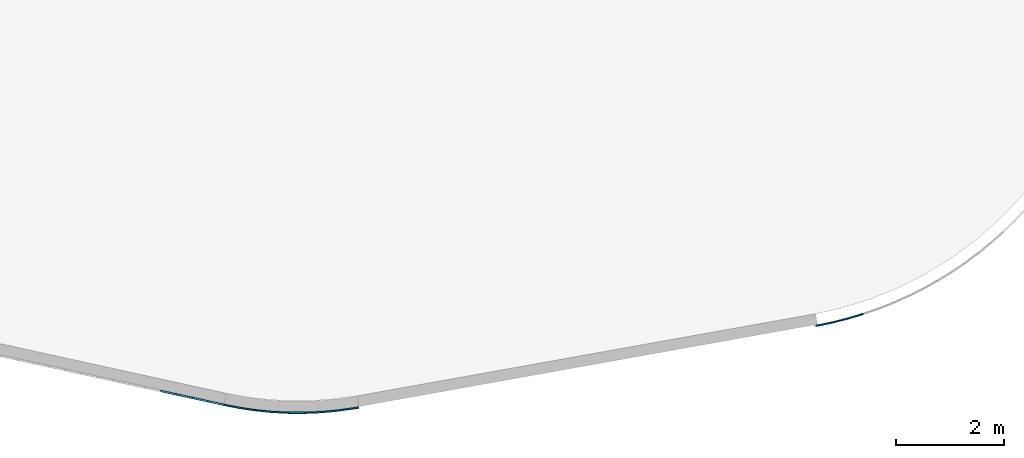
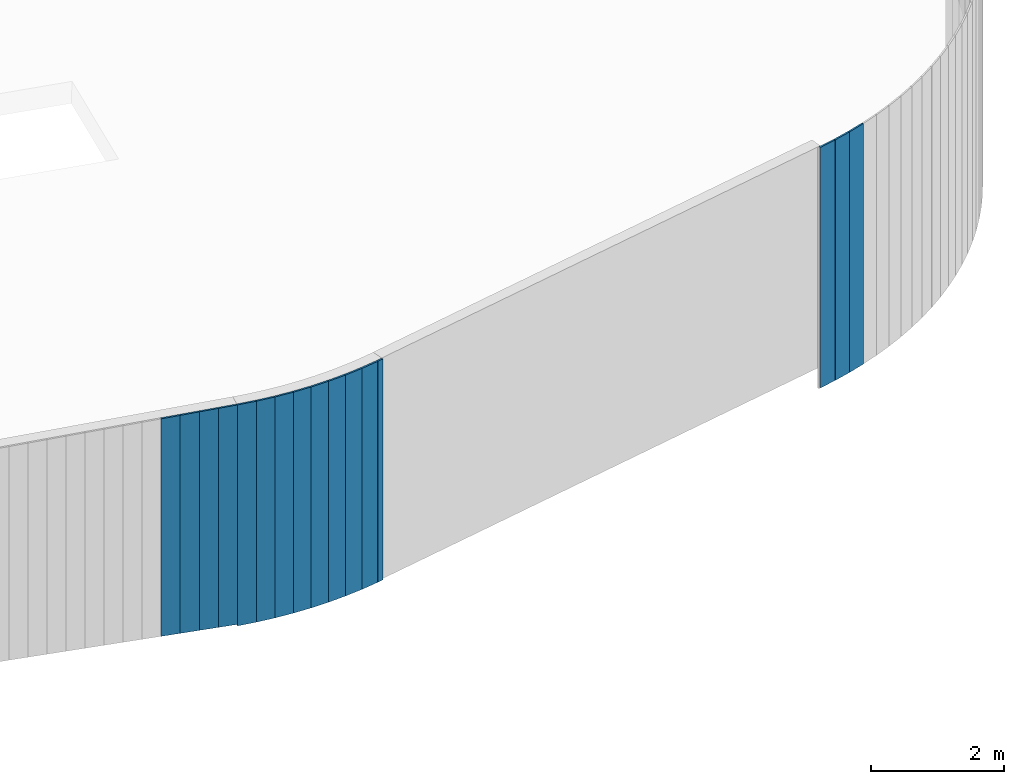
# One storey, part 6 of 18: 16 plates, 3 elements without a shape of their own.
"""IFC2X3 building model written with IfcOpenShell, lengths in centimetres."""

from ifc_helpers import new_model, entity, si_unit, converted_unit, derived_unit, direction, frame, frame_2d, origin, origin_2d_with_axis, place, context, subcontext, project, spatial, polyline, rectangle, outline, extrude, source, transform, mapped, material, layer, layer_set, layer_usage, type_object, type_shapes, element, aggregate, save


model = new_model("IFC2X3")

# Units and contexts
model_context = context("Model", 3, precision=0.001, world=origin(), true_north=direction((6.12303176911189e-17, 1.0)))
body_context = subcontext(model_context, "Body", "Model", "MODEL_VIEW")
ifc_project = project(units=[si_unit("LENGTHUNIT", "METRE", prefix="CENTI"), si_unit("AREAUNIT", "SQUARE_METRE"), si_unit("VOLUMEUNIT", "CUBIC_METRE"), converted_unit("PLANEANGLEUNIT", "DEGREE", entity("IfcRatioMeasure", 0.0174532925199433), si_unit("PLANEANGLEUNIT", "RADIAN"), dimensions=[0, 0, 0, 0, 0, 0, 0]), si_unit("MASSUNIT", "GRAM", prefix="KILO"), derived_unit("MASSDENSITYUNIT", [(si_unit("MASSUNIT", "GRAM", prefix="KILO"), 1), (si_unit("LENGTHUNIT", "METRE"), -3)]), si_unit("TIMEUNIT", "SECOND"), si_unit("FREQUENCYUNIT", "HERTZ"), si_unit("THERMODYNAMICTEMPERATUREUNIT", "DEGREE_CELSIUS"), derived_unit("THERMALTRANSMITTANCEUNIT", [(si_unit("MASSUNIT", "GRAM", prefix="KILO"), 1), (si_unit("THERMODYNAMICTEMPERATUREUNIT", "KELVIN"), -1), (si_unit("TIMEUNIT", "SECOND"), -3)]), derived_unit("VOLUMETRICFLOWRATEUNIT", [(si_unit("LENGTHUNIT", "METRE"), 3), (si_unit("TIMEUNIT", "SECOND"), -1)]), si_unit("ELECTRICCURRENTUNIT", "AMPERE"), si_unit("ELECTRICVOLTAGEUNIT", "VOLT"), si_unit("POWERUNIT", "WATT"), si_unit("FORCEUNIT", "NEWTON", prefix="KILO"), si_unit("ILLUMINANCEUNIT", "LUX"), si_unit("LUMINOUSFLUXUNIT", "LUMEN"), si_unit("LUMINOUSINTENSITYUNIT", "CANDELA"), derived_unit("USERDEFINED", [(si_unit("MASSUNIT", "GRAM", prefix="KILO"), -1), (si_unit("LENGTHUNIT", "METRE"), -2), (si_unit("TIMEUNIT", "SECOND"), 3), (si_unit("LUMINOUSFLUXUNIT", "LUMEN"), 1)]), derived_unit("LINEARVELOCITYUNIT", [(si_unit("LENGTHUNIT", "METRE"), 1), (si_unit("TIMEUNIT", "SECOND"), -1)]), si_unit("PRESSUREUNIT", "PASCAL"), derived_unit("USERDEFINED", [(si_unit("LENGTHUNIT", "METRE"), -2), (si_unit("MASSUNIT", "GRAM", prefix="KILO"), 1), (si_unit("TIMEUNIT", "SECOND"), -2)])], contexts=[model_context])

# Site, building, storey
site_placement = place(None, origin())
site = spatial("IfcSite", under=ifc_project, at=site_placement, CompositionType="ELEMENT")
building_placement = place(site_placement, origin())
building = spatial("IfcBuilding", under=site, at=building_placement, CompositionType="ELEMENT")
storey_placement = place(building_placement, frame((0.0, 0.0, 1422.0)))
storey = spatial("IfcBuildingStorey", under=building, at=storey_placement, CompositionType="ELEMENT", Elevation=1422.0)

# Curtain wall, plates
curtain_wall_type = type_object("IfcCurtainWallType", PredefinedType="NOTDEFINED")
curtain_wall_1_placement = place(storey_placement, frame((0.0, 0.0, -1422.0)))
curtain_wall_1 = element("IfcCurtainWall", 1, at=curtain_wall_1_placement, inside=storey, type_object=curtain_wall_type)
ifc_material = material()
ifc_layer = layer(ifc_material, 3.0)
ifc_layer_set = layer_set([ifc_layer])
ifc_layer_usage_1 = layer_usage(ifc_layer_set, "AXIS3", "POSITIVE", 0.0492125984251968)
plate_type_1 = type_object("IfcPlateType", Name="Panneau plein ST", PredefinedType="CURTAIN_PANEL", material=ifc_layer_set)
shared_shape_1 = source(origin(), body_context, "Body", "SweptSolid", [
    extrude(rectangle(XDim=3.0, YDim=30.0000000000006, at=origin_2d_with_axis()), frame((0.0, 1.49999999999993, 0.0), z_axis=(0.0, 0.0, 1.0), x_axis=(0.0, 1.0, 0.0)), (0.0, 0.0, 1.0), 440.940384027565),
])
type_shapes(plate_type_1, [shared_shape_1])
plate_1_placement = place(curtain_wall_1_placement, frame((9424.45211863919, 323.090890237108, 981.059615972435), z_axis=(0.0, 0.0, 1.0), x_axis=(-0.9582875378238, -0.285805869169265, 0.0)))
plate_1 = element("IfcPlate", 2, at=plate_1_placement, type_object=plate_type_1, material=ifc_layer_usage_1, ObjectType="Panneau plein ST", context=body_context, shape_type="MappedRepresentation", body=[
    mapped(shared_shape_1, transform((0.0, 0.0, 0.0), scale=1.0)),
])
ifc_layer_usage_2 = layer_usage(ifc_layer_set, "AXIS3", "POSITIVE", 0.0492125984251968)
plate_2_placement = place(curtain_wall_1_placement, frame((9395.53072772908, 315.145588668777, 981.059615972435), z_axis=(0.0, 0.0, 1.0), x_axis=(-0.969805189516908, -0.243880902052772, 0.0)))
plate_2 = element("IfcPlate", 3, at=plate_2_placement, type_object=plate_type_1, material=ifc_layer_usage_2, ObjectType="Panneau plein ST", context=body_context, shape_type="MappedRepresentation", body=[
    mapped(shared_shape_1, transform((0.0, 0.0, 0.0), scale=1.0)),
])
ifc_layer_usage_3 = layer_usage(ifc_layer_set, "AXIS3", "POSITIVE", 0.0492125984251968)
plate_3_placement = place(curtain_wall_1_placement, frame((9366.29130647015, 308.464951451428, 981.059615972435), z_axis=(0.0, 0.0, 1.0), x_axis=(-0.979489561078598, -0.201494912437151, 0.0)))
plate_3 = element("IfcPlate", 4, at=plate_3_placement, type_object=plate_type_1, material=ifc_layer_usage_3, ObjectType="Panneau plein ST", context=body_context, shape_type="MappedRepresentation", body=[
    mapped(shared_shape_1, transform((0.0, 0.0, 0.0), scale=1.0)),
])
aggregate(curtain_wall_1, [plate_1, plate_2, plate_3])

curtain_wall_2_placement = place(storey_placement, frame((0.0, 0.0, -1422.0)))
curtain_wall_2 = element("IfcCurtainWall", 5, at=curtain_wall_2_placement, inside=storey, type_object=curtain_wall_type)
ifc_layer_usage_4 = layer_usage(ifc_layer_set, "AXIS3", "POSITIVE", 0.0492125984251968)
plate_type_2 = type_object("IfcPlateType", Name="Panneau plein ST", PredefinedType="CURTAIN_PANEL", material=ifc_layer_set)
shared_shape_2 = source(origin(), body_context, "Body", "SweptSolid", [
    extrude(outline(polyline([(-201.340472043274, -15.0), (200.894816831651, -15.0), (200.894816831652, 15.0), (-200.449161620029, 15.0), (-201.340472043274, -15.0)])), frame((0.0, 0.0, 201.340472043274), z_axis=(0.0, 1.0, 0.0), x_axis=(0.0, 0.0, 1.0)), (0.0, 0.0, 1.0), 3.0),
])
type_shapes(plate_type_2, [shared_shape_2])
plate_4_placement = place(curtain_wall_2_placement, frame((8243.17906349244, 162.56176569563, 1019.76471112607), z_axis=(0.0, 0.0, 1.0), x_axis=(-0.976731958442773, 0.214463706385357, 0.0)))
plate_4 = element("IfcPlate", 6, at=plate_4_placement, type_object=plate_type_2, material=ifc_layer_usage_4, ObjectType="Panneau plein ST", context=body_context, shape_type="MappedRepresentation", body=[
    mapped(shared_shape_2, transform((0.0, 0.0, 0.0), scale=1.0)),
])
ifc_layer_usage_5 = layer_usage(ifc_layer_set, "AXIS3", "POSITIVE", 0.0492125984251968)
plate_type_3 = type_object("IfcPlateType", Name="Panneau plein ST", PredefinedType="CURTAIN_PANEL", material=ifc_layer_set)
shared_shape_3 = source(origin(), body_context, "Body", "SweptSolid", [
    extrude(outline(polyline([(-200.894816831651, -15.0), (200.449161620029, -15.0), (200.449161620029, 15.0), (-200.003506408406, 15.0), (-200.894816831651, -15.0)])), frame((0.0, 0.0, 200.894816831651), z_axis=(0.0, 1.0, 0.0), x_axis=(0.0, 0.0, 1.0)), (0.0, 0.0, 1.0), 3.0),
])
type_shapes(plate_type_3, [shared_shape_3])
plate_5_placement = place(curtain_wall_2_placement, frame((8213.87710473915, 168.995676887191, 1020.65602154832), z_axis=(0.0, 0.0, 1.0), x_axis=(-0.976731958442773, 0.214463706385357, 0.0)))
plate_5 = element("IfcPlate", 7, at=plate_5_placement, type_object=plate_type_3, material=ifc_layer_usage_5, ObjectType="Panneau plein ST", context=body_context, shape_type="MappedRepresentation", body=[
    mapped(shared_shape_3, transform((0.0, 0.0, 0.0), scale=1.0)),
])
ifc_layer_usage_6 = layer_usage(ifc_layer_set, "AXIS3", "POSITIVE", 0.0492125984251968)
plate_type_4 = type_object("IfcPlateType", Name="Panneau plein ST", PredefinedType="CURTAIN_PANEL", material=ifc_layer_set)
shared_shape_4 = source(origin(), body_context, "Body", "SweptSolid", [
    extrude(outline(polyline([(-200.449161620029, -15.0), (200.003506408406, -15.0), (200.003506408406, 15.0), (-199.557851196783, 15.0), (-200.449161620029, -15.0)])), frame((0.0, 0.0, 200.449161620029), z_axis=(0.0, 1.0, 0.0), x_axis=(0.0, 0.0, 1.0)), (0.0, 0.0, 1.0), 3.0),
])
type_shapes(plate_type_4, [shared_shape_4])
plate_6_placement = place(curtain_wall_2_placement, frame((8184.57514598587, 175.429588078752, 1021.54733197157), z_axis=(0.0, 0.0, 1.0), x_axis=(-0.976731958442773, 0.214463706385357, 0.0)))
plate_6 = element("IfcPlate", 8, at=plate_6_placement, type_object=plate_type_4, material=ifc_layer_usage_6, ObjectType="Panneau plein ST", context=body_context, shape_type="MappedRepresentation", body=[
    mapped(shared_shape_4, transform((0.0, 0.0, 0.0), scale=1.0)),
])
ifc_layer_usage_7 = layer_usage(ifc_layer_set, "AXIS3", "POSITIVE", 0.0492125984251968)
plate_type_5 = type_object("IfcPlateType", Name="Panneau plein ST", PredefinedType="CURTAIN_PANEL", material=ifc_layer_set)
shared_shape_5 = source(origin(), body_context, "Body", "SweptSolid", [
    extrude(outline(polyline([(-200.003506408406, -15.0), (199.557851196783, -15.0), (199.557851196783, 15.0), (-199.112195985161, 15.0), (-200.003506408406, -15.0)])), frame((0.0, 0.0, 200.003506408406), z_axis=(0.0, 1.0, 0.0), x_axis=(0.0, 0.0, 1.0)), (0.0, 0.0, 1.0), 3.0),
])
type_shapes(plate_type_5, [shared_shape_5])
plate_7_placement = place(curtain_wall_2_placement, frame((8155.27318723259, 181.863499270312, 1022.43864239481), z_axis=(0.0, 0.0, 1.0), x_axis=(-0.976731958442773, 0.214463706385357, 0.0)))
plate_7 = element("IfcPlate", 9, at=plate_7_placement, type_object=plate_type_5, material=ifc_layer_usage_7, ObjectType="Panneau plein ST", context=body_context, shape_type="MappedRepresentation", body=[
    mapped(shared_shape_5, transform((0.0, 0.0, 0.0), scale=1.0)),
])
aggregate(curtain_wall_2, [plate_4, plate_5, plate_6, plate_7])

curtain_wall_3_placement = place(storey_placement, frame((0.0, 0.0, -1422.0)))
curtain_wall_3 = element("IfcCurtainWall", 10, at=curtain_wall_3_placement, inside=storey, type_object=curtain_wall_type)
ifc_layer_usage_8 = layer_usage(ifc_layer_set, "AXIS3", "POSITIVE", 0.0492125984251968)
plate_type_6 = type_object("IfcPlateType", Name="Panneau plein ST", PredefinedType="CURTAIN_PANEL", material=ifc_layer_set)
shared_shape_6 = source(origin(), body_context, "Body", "SweptSolid", [
    extrude(rectangle(XDim=3.0, YDim=30.0000000000014, at=frame_2d((0.0, -5.32907051820075e-15), x_axis=(1.0, 0.0))), frame((0.0, -1.50000000000019, 0.0), z_axis=(0.0, 0.0, 1.0), x_axis=(0.0, 1.0, 0.0)), (0.0, 0.0, 1.0), 405.0),
])
type_shapes(plate_type_6, [shared_shape_6])
plate_8_placement = place(curtain_wall_3_placement, frame((8272.59302665952, 156.466451872095, 1017.0), z_axis=(0.0, 0.0, 1.0), x_axis=(0.981530702078089, -0.191304680753224, 0.0)))
plate_8 = element("IfcPlate", 11, at=plate_8_placement, type_object=plate_type_6, material=ifc_layer_usage_8, ObjectType="Panneau plein ST", context=body_context, shape_type="MappedRepresentation", body=[
    mapped(shared_shape_6, transform((0.0, 0.0, 0.0), scale=1.0)),
])
ifc_layer_usage_9 = layer_usage(ifc_layer_set, "AXIS3", "POSITIVE", 0.0492125984251968)
plate_9_placement = place(curtain_wall_3_placement, frame((8302.15788792795, 151.424789925786, 1017.0), z_axis=(0.0, 0.0, 1.0), x_axis=(0.989460049150702, -0.144806115667436, 0.0)))
plate_9 = element("IfcPlate", 12, at=plate_9_placement, type_object=plate_type_6, material=ifc_layer_usage_9, ObjectType="Panneau plein ST", context=body_context, shape_type="MappedRepresentation", body=[
    mapped(shared_shape_6, transform((0.0, 0.0, 0.0), scale=1.0)),
])
ifc_layer_usage_10 = layer_usage(ifc_layer_set, "AXIS3", "POSITIVE", 0.0492125984251968)
plate_10_placement = place(curtain_wall_3_placement, frame((8331.92760651151, 147.782917816829, 1017.0), z_axis=(0.0, 0.0, 1.0), x_axis=(0.995187856420114, -0.0979853582630507, 0.0)))
plate_10 = element("IfcPlate", 13, at=plate_10_placement, type_object=plate_type_6, material=ifc_layer_usage_10, ObjectType="Panneau plein ST", context=body_context, shape_type="MappedRepresentation", body=[
    mapped(shared_shape_6, transform((0.0, 0.0, 0.0), scale=1.0)),
])
ifc_layer_usage_11 = layer_usage(ifc_layer_set, "AXIS3", "POSITIVE", 0.0492125984251968)
plate_11_placement = place(curtain_wall_3_placement, frame((8361.8359450513, 145.548938678254, 1017.0), z_axis=(0.0, 0.0, 1.0), x_axis=(0.998701379566128, -0.0509465843085984, 0.0)))
plate_11 = element("IfcPlate", 14, at=plate_11_placement, type_object=plate_type_6, material=ifc_layer_usage_11, ObjectType="Panneau plein ST", context=body_context, shape_type="MappedRepresentation", body=[
    mapped(shared_shape_6, transform((0.0, 0.0, 0.0), scale=1.0)),
])
ifc_layer_usage_12 = layer_usage(ifc_layer_set, "AXIS3", "POSITIVE", 0.0492125984251968)
plate_12_placement = place(curtain_wall_3_placement, frame((8391.81635776026, 144.727823093763, 1017.0), z_axis=(0.0, 0.0, 1.0), x_axis=(0.999992801031014, -0.00379445465748617, 0.0)))
plate_12 = element("IfcPlate", 15, at=plate_12_placement, type_object=plate_type_6, material=ifc_layer_usage_12, ObjectType="Panneau plein ST", context=body_context, shape_type="MappedRepresentation", body=[
    mapped(shared_shape_6, transform((0.0, 0.0, 0.0), scale=1.0)),
])
ifc_layer_usage_13 = layer_usage(ifc_layer_set, "AXIS3", "POSITIVE", 0.0492125984251968)
plate_13_placement = place(curtain_wall_3_placement, frame((8421.80213848693, 145.321398038222, 1017.0), z_axis=(0.0, 0.0, 1.0), x_axis=(0.999059247413506, 0.0433661176214727, 0.0)))
plate_13 = element("IfcPlate", 16, at=plate_13_placement, type_object=plate_type_6, material=ifc_layer_usage_13, ObjectType="Panneau plein ST", context=body_context, shape_type="MappedRepresentation", body=[
    mapped(shared_shape_6, transform((0.0, 0.0, 0.0), scale=1.0)),
])
ifc_layer_usage_14 = layer_usage(ifc_layer_set, "AXIS3", "POSITIVE", 0.0492125984251968)
plate_14_placement = place(curtain_wall_3_placement, frame((8451.72656913606, 147.328342812665, 1017.0), z_axis=(0.0, 0.0, 1.0), x_axis=(0.995902795862095, 0.0904302006746821, 0.0)))
plate_14 = element("IfcPlate", 17, at=plate_14_placement, type_object=plate_type_6, material=ifc_layer_usage_14, ObjectType="Panneau plein ST", context=body_context, shape_type="MappedRepresentation", body=[
    mapped(shared_shape_6, transform((0.0, 0.0, 0.0), scale=1.0)),
])
ifc_layer_usage_15 = layer_usage(ifc_layer_set, "AXIS3", "POSITIVE", 0.0492125984251968)
plate_15_placement = place(curtain_wall_3_placement, frame((8481.52306811579, 150.744191982828, 1017.0), z_axis=(0.0, 0.0, 1.0), x_axis=(0.99053046945339, 0.137293077336212, 0.0)))
plate_15 = element("IfcPlate", 18, at=plate_15_placement, type_object=plate_type_6, material=ifc_layer_usage_15, ObjectType="Panneau plein ST", context=body_context, shape_type="MappedRepresentation", body=[
    mapped(shared_shape_6, transform((0.0, 0.0, 0.0), scale=1.0)),
])
ifc_layer_usage_16 = layer_usage(ifc_layer_set, "AXIS3", "POSITIVE", 0.0492125984251968)
plate_type_7 = type_object("IfcPlateType", Name="Panneau plein ST", PredefinedType="CURTAIN_PANEL", material=ifc_layer_set)
shared_shape_7 = source(origin(), body_context, "Body", "SweptSolid", [
    extrude(rectangle(XDim=3.0, YDim=10.1847819020687, at=origin_2d_with_axis()), frame((0.0, -1.49999999999997, 0.0), z_axis=(0.0, 0.0, 1.0), x_axis=(0.0, 1.0, 0.0)), (0.0, 0.0, 1.0), 405.0),
])
type_shapes(plate_type_7, [shared_shape_7])
plate_16_placement = place(curtain_wall_3_placement, frame((8501.40059092837, 153.661728615658, 1017.0), z_axis=(0.0, 0.0, 1.0), x_axis=(0.985699216545027, 0.16851425608096, 0.0)))
plate_16 = element("IfcPlate", 19, at=plate_16_placement, type_object=plate_type_7, material=ifc_layer_usage_16, ObjectType="Panneau plein ST", context=body_context, shape_type="MappedRepresentation", body=[
    mapped(shared_shape_7, transform((0.0, 0.0, 0.0), scale=1.0)),
])
aggregate(curtain_wall_3, [plate_8, plate_9, plate_10, plate_11, plate_12, plate_13, plate_14, plate_15, plate_16])

save(model, "model.ifc")
